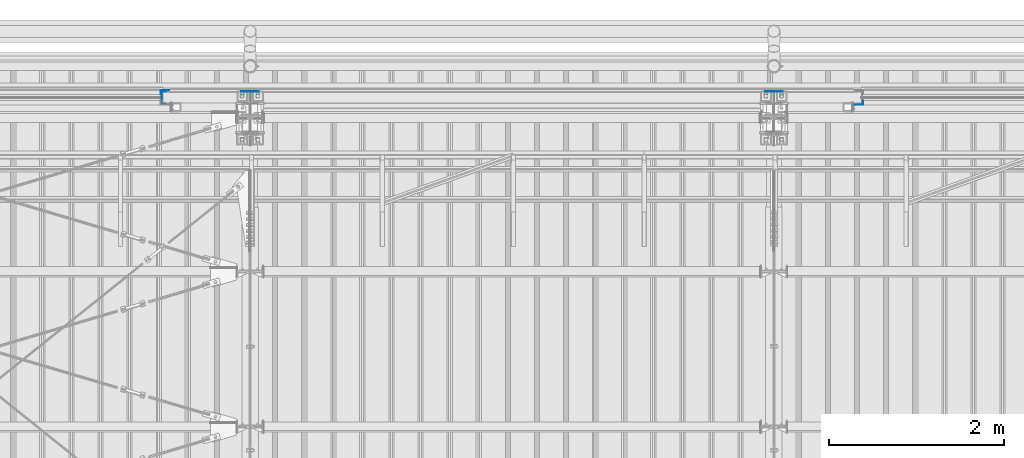
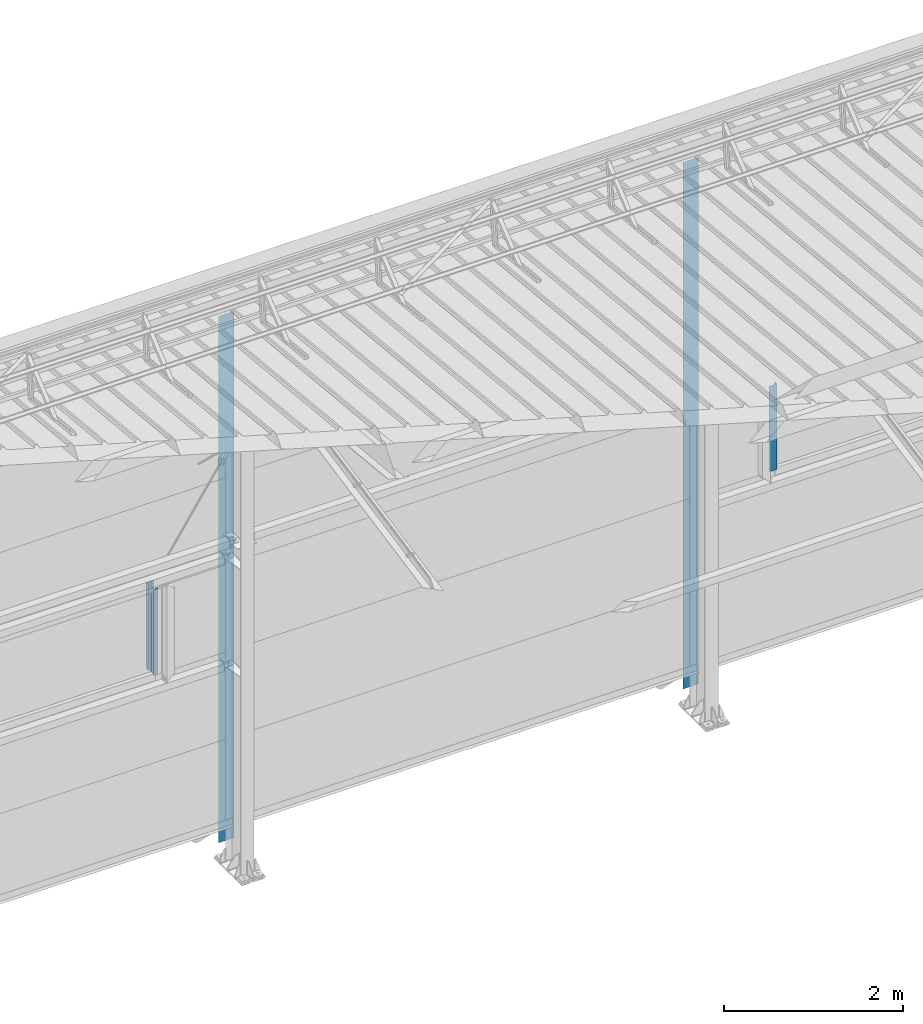
# One storey, part 9 of 709: 5 columns, 5 elements without a shape of their own.
"""IFC4 building model written with IfcOpenShell, lengths in millimetres."""

from ifc_helpers import new_model, si_unit, direction, frame, origin_with_axes, place, context, subcontext, project, spatial, line, indexed_curve, outline, extrude, material, element, aggregate, save


model = new_model("IFC4")

# Units and contexts
model_context = context("Model", 3, precision=0.2, world=origin_with_axes(), true_north=direction((0.0, 1.0)))
body_context = subcontext(model_context, "Body", "Model", "MODEL_VIEW")
ifc_project = project(units=[si_unit("LENGTHUNIT", "METRE", prefix="MILLI"), si_unit("AREAUNIT", "SQUARE_METRE"), si_unit("VOLUMEUNIT", "CUBIC_METRE"), si_unit("MASSUNIT", "GRAM", prefix="KILO"), si_unit("TIMEUNIT", "SECOND"), si_unit("PLANEANGLEUNIT", "RADIAN"), si_unit("SOLIDANGLEUNIT", "STERADIAN"), si_unit("THERMODYNAMICTEMPERATUREUNIT", "DEGREE_CELSIUS"), si_unit("LUMINOUSINTENSITYUNIT", "LUMEN")], contexts=[model_context])

# Site, building, storey
site_placement = place(None, origin_with_axes())
site = spatial("IfcSite", under=ifc_project, at=site_placement, CompositionType="ELEMENT")
building_placement = place(site_placement, origin_with_axes())
building = spatial("IfcBuilding", under=site, at=building_placement, Name="Undefined", CompositionType="ELEMENT")
storey_placement = place(building_placement, origin_with_axes())
storey = spatial("IfcBuildingStorey", under=building, at=storey_placement, Name="Undefined", CompositionType="ELEMENT", Elevation=0.0)

# Assembly, column
assembly_1_placement = place(storey_placement, frame((9010.0, 22060.0, 2700.0), z_axis=(0.0, -1.0, 0.0), x_axis=(0.0, 0.0, 1.0)))
assembly_1 = element("IfcElementAssembly", 1, at=assembly_1_placement, inside=storey)
ifc_material = material(Name="Steel_Undefined", Category="STEEL")
column_1_placement = place(assembly_1_placement, origin_with_axes())
column_1 = element("IfcColumn", 2, at=column_1_placement, material=ifc_material, context=body_context, shape_type="SolidModel", body=[
    extrude(outline(indexed_curve([(-70.0, -25.0), (-68.0, -25.0), (-68.0, 23.0), (68.0, 23.0), (68.0, -25.0), (70.0, -25.0), (70.0, 25.0), (-70.0, 25.0)], segments=[line(1, 2, 3, 4, 5, 6, 7, 8, 1)])), frame((0.0, 0.0, 0.0), z_axis=(-1.0, 0.0, 0.0), x_axis=(0.0, 0.0, 1.0)), (0.0, 0.0, -1.0), 1170.0),
])
aggregate(assembly_1, [column_1])

assembly_2_placement = place(storey_placement, frame((8975.0, 22121.0, 2700.0), z_axis=(0.0, 1.0, 0.0), x_axis=(0.0, 0.0, 1.0)))
assembly_2 = element("IfcElementAssembly", 3, at=assembly_2_placement, inside=storey)
column_2_placement = place(assembly_2_placement, origin_with_axes())
column_2 = element("IfcColumn", 4, at=column_2_placement, material=ifc_material, context=body_context, shape_type="SolidModel", body=[
    extrude(outline(indexed_curve([(-25.0, -1.0), (25.0, -1.0), (25.0, 99.0), (23.0, 99.0), (23.0, 1.0), (-25.0, 1.0)], segments=[line(1, 2, 3, 4, 5, 6, 1)])), frame((0.0, 0.0, 0.0), z_axis=(-1.0, 0.0, 0.0), x_axis=(0.0, 0.0, 1.0)), (0.0, 0.0, -1.0), 1170.0),
])
aggregate(assembly_2, [column_2])

assembly_3_placement = place(storey_placement, frame((17025.0, 22001.0, 2700.0), z_axis=(0.0, -1.0, 0.0), x_axis=(0.0, 0.0, 1.0)))
assembly_3 = element("IfcElementAssembly", 5, at=assembly_3_placement, inside=storey)
column_3_placement = place(assembly_3_placement, origin_with_axes())
column_3 = element("IfcColumn", 6, at=column_3_placement, material=ifc_material, context=body_context, shape_type="SolidModel", body=[
    extrude(outline(indexed_curve([(-25.0, -1.0), (25.0, -1.0), (25.0, 99.0), (23.0, 99.0), (23.0, 1.0), (-25.0, 1.0)], segments=[line(1, 2, 3, 4, 5, 6, 1)])), frame((0.0, 0.0, 0.0), z_axis=(-1.0, 0.0, 0.0), x_axis=(0.0, 0.0, 1.0)), (0.0, 0.0, -1.0), 1170.0),
])
aggregate(assembly_3, [column_3])

assembly_4_placement = place(storey_placement, frame((10000.0, 22130.0, 0.0), z_axis=(0.0, -1.0, 0.0), x_axis=(0.0, 0.0, 1.0)))
assembly_4 = element("IfcElementAssembly", 7, at=assembly_4_placement, inside=storey)
column_4_placement = place(assembly_4_placement, origin_with_axes())
column_4 = element("IfcColumn", 8, at=column_4_placement, material=ifc_material, context=body_context, shape_type="SolidModel", body=[
    extrude(outline(indexed_curve([(-0.375, -100.0), (1.245, -100.0), (1.245, -50.0), (0.495, -50.0), (0.495, -99.25), (0.375, -99.25), (0.375, 99.25), (0.495, 99.25), (0.495, 50.0), (1.245, 50.0), (1.245, 100.0), (-0.375, 100.0)], segments=[line(1, 2, 3, 4, 5, 6, 7, 8, 9, 10, 11, 12, 1)])), frame((0.0, 0.0, 0.0), z_axis=(-1.0, 0.0, 0.0), x_axis=(0.0, 0.0, 1.0)), (0.0, 0.0, -1.0), 7196.92297),
])
aggregate(assembly_4, [column_4])

assembly_5_placement = place(storey_placement, frame((16000.0, 22130.0, 0.0), z_axis=(0.0, -1.0, 0.0), x_axis=(0.0, 0.0, 1.0)))
assembly_5 = element("IfcElementAssembly", 9, at=assembly_5_placement, inside=storey)
column_5_placement = place(assembly_5_placement, origin_with_axes())
column_5 = element("IfcColumn", 10, at=column_5_placement, material=ifc_material, context=body_context, shape_type="SolidModel", body=[
    extrude(outline(indexed_curve([(-0.375, -100.0), (1.245, -100.0), (1.245, -50.0), (0.495, -50.0), (0.495, -99.25), (0.375, -99.25), (0.375, 99.25), (0.495, 99.25), (0.495, 50.0), (1.245, 50.0), (1.245, 100.0), (-0.375, 100.0)], segments=[line(1, 2, 3, 4, 5, 6, 7, 8, 9, 10, 11, 12, 1)])), frame((0.0, 0.0, 0.0), z_axis=(-1.0, 0.0, 0.0), x_axis=(0.0, 0.0, 1.0)), (0.0, 0.0, -1.0), 7196.92297),
])
aggregate(assembly_5, [column_5])

save(model, "model.ifc")
